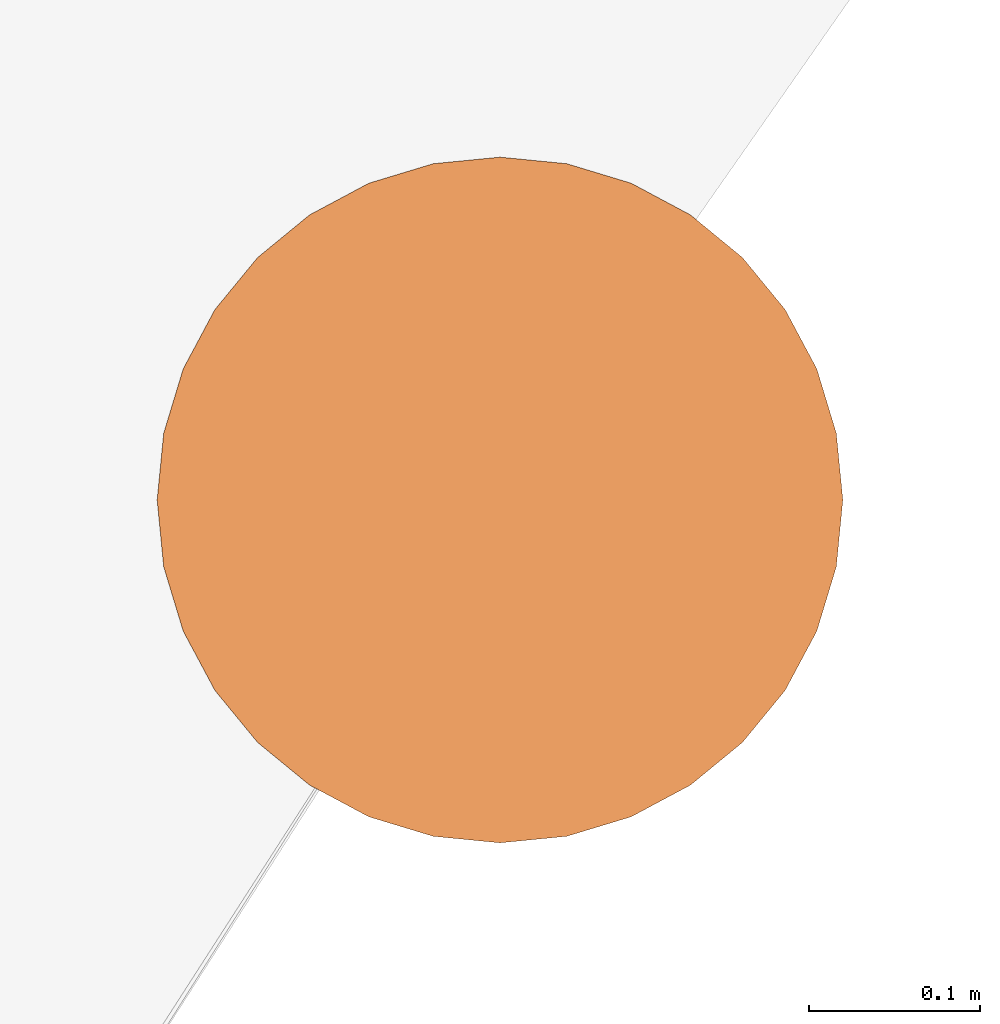
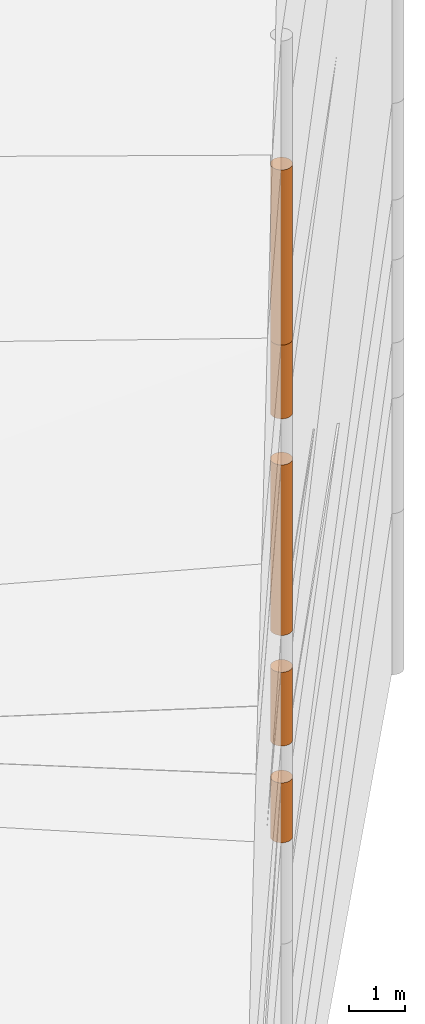
# One storey, part 16 of 24: 5 geographic elements.
"""IFC4 building model written with IfcOpenShell, lengths in metres."""

from ifc_helpers import new_model, entity, si_unit, converted_unit, frame, origin_with_axes, origin_2d_with_axis, place, context, subcontext, project, spatial, polygons, element, save


model = new_model("IFC4")

# Units and contexts
model_context = context("Model", 3, precision=1e-05, world=origin_with_axes())
plan_context = context("Plan", 2, precision=1e-05, world=origin_2d_with_axis())
body_context = subcontext(model_context, "Body", "Model", "MODEL_VIEW")
ifc_project = project(units=[converted_unit("PLANEANGLEUNIT", "degree", entity("IfcReal", 0.0174532925199433), si_unit("PLANEANGLEUNIT", "RADIAN"), dimensions=[0, 0, 0, 0, 0, 0, 0]), si_unit("AREAUNIT", "SQUARE_METRE"), si_unit("VOLUMEUNIT", "CUBIC_METRE"), si_unit("LENGTHUNIT", "METRE")], contexts=[model_context, plan_context])

# Site, building, storey
site_placement = place(None, origin_with_axes())
site = spatial("IfcSite", under=ifc_project, at=site_placement)
building_placement = place(site_placement, origin_with_axes())
building = spatial("IfcBuilding", under=site, at=building_placement, Name="Building")
storey_placement = place(building_placement, origin_with_axes())
storey = spatial("IfcBuildingStorey", under=building, at=storey_placement, Name="Storey")

# Geographic elements
geographic_element_1_placement = place(storey_placement, frame((36.5, 56.7999992370605, 0.150000095367432), z_axis=(0.0, 0.0, 1.0), x_axis=(1.0, 0.0, 0.0)))
element("IfcGeographicElement", 1, at=geographic_element_1_placement, inside=storey, PredefinedType="NOTDEFINED", context=body_context, shape_type="Tessellation", body=[
    polygons([(0.0, 0.0, -0.649999916553497), (0.0390180610120296, 0.196157038211823, -0.649999916553497), (0.0, 0.199999988079071, -0.649999916553497), (0.0, 0.0, 0.649999916553497), (0.0, 0.199999988079071, 0.649999916553497), (0.0390180610120296, 0.196157038211823, 0.649999916553497), (0.0765366926789284, 0.18477588891983, -0.649999916553497), (0.0765366926789284, 0.18477588891983, 0.649999916553497), (0.111114047467709, 0.166293919086456, -0.649999916553497), (0.111114047467709, 0.166293919086456, 0.649999916553497), (0.141421362757683, 0.141421362757683, -0.649999916553497), (0.141421362757683, 0.141421362757683, 0.649999916553497), (0.166293919086456, 0.111114047467709, -0.649999916553497), (0.166293919086456, 0.111114047467709, 0.649999916553497), (0.18477588891983, 0.0765366926789284, -0.649999916553497), (0.18477588891983, 0.0765366926789284, 0.649999916553497), (0.196157038211823, 0.0390180610120296, -0.649999916553497), (0.196157038211823, 0.0390180610120296, 0.649999916553497), (0.199999988079071, 0.0, -0.649999916553497), (0.199999988079071, 0.0, 0.649999916553497), (0.196157038211823, -0.0390180610120296, -0.649999916553497), (0.196157038211823, -0.0390180610120296, 0.649999916553497), (0.18477588891983, -0.0765366926789284, -0.649999916553497), (0.18477588891983, -0.0765366926789284, 0.649999916553497), (0.166293919086456, -0.111114047467709, -0.649999916553497), (0.166293919086456, -0.111114047467709, 0.649999916553497), (0.141421362757683, -0.141421362757683, -0.649999916553497), (0.141421362757683, -0.141421362757683, 0.649999916553497), (0.111114047467709, -0.166293919086456, -0.649999916553497), (0.111114047467709, -0.166293919086456, 0.649999916553497), (0.0765366926789284, -0.18477588891983, -0.649999916553497), (0.0765366926789284, -0.18477588891983, 0.649999916553497), (0.0390180610120296, -0.196157038211823, -0.649999916553497), (0.0390180610120296, -0.196157038211823, 0.649999916553497), (0.0, -0.199999988079071, -0.649999916553497), (0.0, -0.199999988079071, 0.649999916553497), (-0.0390180610120296, -0.196157038211823, -0.649999916553497), (-0.0390180610120296, -0.196157038211823, 0.649999916553497), (-0.0765366926789284, -0.18477588891983, -0.649999916553497), (-0.0765366926789284, -0.18477588891983, 0.649999916553497), (-0.111114047467709, -0.166293919086456, -0.649999916553497), (-0.111114047467709, -0.166293919086456, 0.649999916553497), (-0.141421362757683, -0.141421362757683, -0.649999916553497), (-0.141421362757683, -0.141421362757683, 0.649999916553497), (-0.166293919086456, -0.111114047467709, -0.649999916553497), (-0.166293919086456, -0.111114047467709, 0.649999916553497), (-0.18477588891983, -0.0765366926789284, -0.649999916553497), (-0.18477588891983, -0.0765366926789284, 0.649999916553497), (-0.196157038211823, -0.0390180610120296, -0.649999916553497), (-0.196157038211823, -0.0390180610120296, 0.649999916553497), (-0.199999988079071, 0.0, -0.649999916553497), (-0.199999988079071, 0.0, 0.649999916553497), (-0.196157038211823, 0.0390180610120296, -0.649999916553497), (-0.196157038211823, 0.0390180610120296, 0.649999916553497), (-0.18477588891983, 0.0765366926789284, -0.649999916553497), (-0.18477588891983, 0.0765366926789284, 0.649999916553497), (-0.166293919086456, 0.111114047467709, -0.649999916553497), (-0.166293919086456, 0.111114047467709, 0.649999916553497), (-0.141421362757683, 0.141421362757683, -0.649999916553497), (-0.141421362757683, 0.141421362757683, 0.649999916553497), (-0.111114047467709, 0.166293919086456, -0.649999916553497), (-0.111114047467709, 0.166293919086456, 0.649999916553497), (-0.0765366926789284, 0.18477588891983, -0.649999916553497), (-0.0765366926789284, 0.18477588891983, 0.649999916553497), (-0.0390180610120296, 0.196157038211823, -0.649999916553497), (-0.0390180610120296, 0.196157038211823, 0.649999916553497)], [[[3, 2, 1]], [[6, 5, 4]], [[32, 34, 33, 31]], [[2, 7, 1]], [[8, 6, 4]], [[64, 66, 65, 63]], [[7, 9, 1]], [[10, 8, 4]], [[9, 11, 1]], [[12, 10, 4]], [[40, 42, 41, 39]], [[1, 11, 13]], [[12, 4, 14]], [[10, 12, 11, 9]], [[1, 13, 15]], [[4, 16, 14]], [[12, 14, 13, 11]], [[1, 15, 17]], [[4, 18, 16]], [[18, 20, 19, 17]], [[1, 17, 19]], [[4, 20, 18]], [[20, 22, 21, 19]], [[1, 19, 21]], [[4, 22, 20]], [[22, 24, 23, 21]], [[1, 21, 23]], [[22, 4, 24]], [[54, 56, 55, 53]], [[1, 23, 25]], [[24, 4, 26]], [[56, 58, 57, 55]], [[1, 25, 27]], [[4, 28, 26]], [[24, 26, 25, 23]], [[1, 27, 29]], [[28, 4, 30]], [[26, 28, 27, 25]], [[1, 29, 31]], [[4, 32, 30]], [[46, 48, 47, 45]], [[1, 31, 33]], [[4, 34, 32]], [[36, 38, 37, 35]], [[1, 33, 35]], [[4, 36, 34]], [[42, 44, 43, 41]], [[1, 35, 37]], [[4, 38, 36]], [[38, 40, 39, 37]], [[1, 37, 39]], [[4, 40, 38]], [[34, 36, 35, 33]], [[1, 39, 41]], [[4, 42, 40]], [[8, 10, 9, 7]], [[43, 1, 41]], [[4, 44, 42]], [[44, 46, 45, 43]], [[43, 45, 1]], [[4, 46, 44]], [[30, 32, 31, 29]], [[47, 1, 45]], [[48, 46, 4]], [[28, 30, 29, 27]], [[49, 1, 47]], [[50, 48, 4]], [[5, 6, 2, 3]], [[49, 51, 1]], [[52, 50, 4]], [[48, 50, 49, 47]], [[51, 53, 1]], [[54, 52, 4]], [[50, 52, 51, 49]], [[53, 55, 1]], [[4, 56, 54]], [[52, 54, 53, 51]], [[55, 57, 1]], [[4, 58, 56]], [[58, 60, 59, 57]], [[59, 1, 57]], [[60, 58, 4]], [[60, 62, 61, 59]], [[59, 61, 1]], [[62, 60, 4]], [[62, 64, 63, 61]], [[61, 63, 1]], [[64, 62, 4]], [[14, 16, 15, 13]], [[63, 65, 1]], [[66, 64, 4]], [[16, 18, 17, 15]], [[65, 3, 1]], [[5, 66, 4]], [[6, 8, 7, 2]], [[66, 5, 3, 65]]]),
])
geographic_element_2_placement = place(storey_placement, frame((36.5, 56.7999992370605, 2.40000009536743), z_axis=(0.0, 0.0, 1.0), x_axis=(1.0, 0.0, 0.0)))
element("IfcGeographicElement", 2, at=geographic_element_2_placement, inside=storey, PredefinedType="NOTDEFINED", context=body_context, shape_type="Tessellation", body=[
    polygons([(0.0, 0.0, -0.799999952316284), (0.0390180610120296, 0.196157038211823, -0.799999952316284), (0.0, 0.199999988079071, -0.799999952316284), (0.0, 0.0, 0.799999952316284), (0.0, 0.199999988079071, 0.799999952316284), (0.0390180610120296, 0.196157038211823, 0.799999952316284), (0.0765366926789284, 0.18477588891983, -0.799999952316284), (0.0765366926789284, 0.18477588891983, 0.799999952316284), (0.111114047467709, 0.166293919086456, -0.799999952316284), (0.111114047467709, 0.166293919086456, 0.799999952316284), (0.141421362757683, 0.141421362757683, -0.799999952316284), (0.141421362757683, 0.141421362757683, 0.799999952316284), (0.166293919086456, 0.111114047467709, -0.799999952316284), (0.166293919086456, 0.111114047467709, 0.799999952316284), (0.18477588891983, 0.0765366926789284, -0.799999952316284), (0.18477588891983, 0.0765366926789284, 0.799999952316284), (0.196157038211823, 0.0390180610120296, -0.799999952316284), (0.196157038211823, 0.0390180610120296, 0.799999952316284), (0.199999988079071, 0.0, -0.799999952316284), (0.199999988079071, 0.0, 0.799999952316284), (0.196157038211823, -0.0390180610120296, -0.799999952316284), (0.196157038211823, -0.0390180610120296, 0.799999952316284), (0.18477588891983, -0.0765366926789284, -0.799999952316284), (0.18477588891983, -0.0765366926789284, 0.799999952316284), (0.166293919086456, -0.111114047467709, -0.799999952316284), (0.166293919086456, -0.111114047467709, 0.799999952316284), (0.141421362757683, -0.141421362757683, -0.799999952316284), (0.141421362757683, -0.141421362757683, 0.799999952316284), (0.111114047467709, -0.166293919086456, -0.799999952316284), (0.111114047467709, -0.166293919086456, 0.799999952316284), (0.0765366926789284, -0.18477588891983, -0.799999952316284), (0.0765366926789284, -0.18477588891983, 0.799999952316284), (0.0390180610120296, -0.196157038211823, -0.799999952316284), (0.0390180610120296, -0.196157038211823, 0.799999952316284), (0.0, -0.199999988079071, -0.799999952316284), (0.0, -0.199999988079071, 0.799999952316284), (-0.0390180610120296, -0.196157038211823, -0.799999952316284), (-0.0390180610120296, -0.196157038211823, 0.799999952316284), (-0.0765366926789284, -0.18477588891983, -0.799999952316284), (-0.0765366926789284, -0.18477588891983, 0.799999952316284), (-0.111114047467709, -0.166293919086456, -0.799999952316284), (-0.111114047467709, -0.166293919086456, 0.799999952316284), (-0.141421362757683, -0.141421362757683, -0.799999952316284), (-0.141421362757683, -0.141421362757683, 0.799999952316284), (-0.166293919086456, -0.111114047467709, -0.799999952316284), (-0.166293919086456, -0.111114047467709, 0.799999952316284), (-0.18477588891983, -0.0765366926789284, -0.799999952316284), (-0.18477588891983, -0.0765366926789284, 0.799999952316284), (-0.196157038211823, -0.0390180610120296, -0.799999952316284), (-0.196157038211823, -0.0390180610120296, 0.799999952316284), (-0.199999988079071, 0.0, -0.799999952316284), (-0.199999988079071, 0.0, 0.799999952316284), (-0.196157038211823, 0.0390180610120296, -0.799999952316284), (-0.196157038211823, 0.0390180610120296, 0.799999952316284), (-0.18477588891983, 0.0765366926789284, -0.799999952316284), (-0.18477588891983, 0.0765366926789284, 0.799999952316284), (-0.166293919086456, 0.111114047467709, -0.799999952316284), (-0.166293919086456, 0.111114047467709, 0.799999952316284), (-0.141421362757683, 0.141421362757683, -0.799999952316284), (-0.141421362757683, 0.141421362757683, 0.799999952316284), (-0.111114047467709, 0.166293919086456, -0.799999952316284), (-0.111114047467709, 0.166293919086456, 0.799999952316284), (-0.0765366926789284, 0.18477588891983, -0.799999952316284), (-0.0765366926789284, 0.18477588891983, 0.799999952316284), (-0.0390180610120296, 0.196157038211823, -0.799999952316284), (-0.0390180610120296, 0.196157038211823, 0.799999952316284)], [[[3, 2, 1]], [[6, 5, 4]], [[28, 30, 29, 27]], [[2, 7, 1]], [[8, 6, 4]], [[36, 38, 37, 35]], [[7, 9, 1]], [[10, 8, 4]], [[56, 58, 57, 55]], [[9, 11, 1]], [[12, 10, 4]], [[58, 60, 59, 57]], [[11, 13, 1]], [[12, 4, 14]], [[54, 56, 55, 53]], [[1, 13, 15]], [[14, 4, 16]], [[10, 12, 11, 9]], [[1, 15, 17]], [[4, 18, 16]], [[60, 62, 61, 59]], [[1, 17, 19]], [[4, 20, 18]], [[16, 18, 17, 15]], [[1, 19, 21]], [[4, 22, 20]], [[18, 20, 19, 17]], [[1, 21, 23]], [[4, 24, 22]], [[20, 22, 21, 19]], [[1, 23, 25]], [[24, 4, 26]], [[22, 24, 23, 21]], [[27, 1, 25]], [[26, 4, 28]], [[24, 26, 25, 23]], [[1, 27, 29]], [[28, 4, 30]], [[62, 64, 63, 61]], [[1, 29, 31]], [[4, 32, 30]], [[64, 66, 65, 63]], [[1, 31, 33]], [[4, 34, 32]], [[30, 32, 31, 29]], [[1, 33, 35]], [[4, 36, 34]], [[8, 10, 9, 7]], [[1, 35, 37]], [[4, 38, 36]], [[32, 34, 33, 31]], [[1, 37, 39]], [[4, 40, 38]], [[6, 8, 7, 2]], [[1, 39, 41]], [[4, 42, 40]], [[38, 40, 39, 37]], [[43, 1, 41]], [[4, 44, 42]], [[40, 42, 41, 39]], [[45, 1, 43]], [[46, 44, 4]], [[42, 44, 43, 41]], [[47, 1, 45]], [[4, 48, 46]], [[44, 46, 45, 43]], [[47, 49, 1]], [[50, 48, 4]], [[46, 48, 47, 45]], [[49, 51, 1]], [[52, 50, 4]], [[48, 50, 49, 47]], [[51, 53, 1]], [[54, 52, 4]], [[66, 5, 3, 65]], [[53, 55, 1]], [[56, 54, 4]], [[52, 54, 53, 51]], [[57, 1, 55]], [[4, 58, 56]], [[57, 59, 1]], [[60, 58, 4]], [[34, 36, 35, 33]], [[59, 61, 1]], [[62, 60, 4]], [[14, 16, 15, 13]], [[61, 63, 1]], [[64, 62, 4]], [[26, 28, 27, 25]], [[63, 65, 1]], [[66, 64, 4]], [[5, 6, 2, 3]], [[65, 3, 1]], [[5, 66, 4]], [[50, 52, 51, 49]], [[12, 14, 13, 11]]]),
])
geographic_element_3_placement = place(storey_placement, frame((36.5, 56.7999992370605, 5.85000038146973), z_axis=(0.0, 0.0, 1.0), x_axis=(1.0, 0.0, 0.0)))
element("IfcGeographicElement", 3, at=geographic_element_3_placement, inside=storey, PredefinedType="NOTDEFINED", context=body_context, shape_type="Tessellation", body=[
    polygons([(0.0, 0.0, -1.84999990463257), (0.0390180610120296, 0.196157038211823, -1.84999990463257), (0.0, 0.199999988079071, -1.84999990463257), (0.0, 0.0, 1.84999990463257), (0.0, 0.199999988079071, 1.84999990463257), (0.0390180610120296, 0.196157038211823, 1.84999990463257), (0.0765366926789284, 0.18477588891983, -1.84999990463257), (0.0765366926789284, 0.18477588891983, 1.84999990463257), (0.111114047467709, 0.166293919086456, -1.84999990463257), (0.111114047467709, 0.166293919086456, 1.84999990463257), (0.141421362757683, 0.141421362757683, -1.84999990463257), (0.141421362757683, 0.141421362757683, 1.84999990463257), (0.166293919086456, 0.111114047467709, -1.84999990463257), (0.166293919086456, 0.111114047467709, 1.84999990463257), (0.18477588891983, 0.0765366926789284, -1.84999990463257), (0.18477588891983, 0.0765366926789284, 1.84999990463257), (0.196157038211823, 0.0390180610120296, -1.84999990463257), (0.196157038211823, 0.0390180610120296, 1.84999990463257), (0.199999988079071, 0.0, -1.84999990463257), (0.199999988079071, 0.0, 1.84999990463257), (0.196157038211823, -0.0390180610120296, -1.84999990463257), (0.196157038211823, -0.0390180610120296, 1.84999990463257), (0.18477588891983, -0.0765366926789284, -1.84999990463257), (0.18477588891983, -0.0765366926789284, 1.84999990463257), (0.166293919086456, -0.111114047467709, -1.84999990463257), (0.166293919086456, -0.111114047467709, 1.84999990463257), (0.141421362757683, -0.141421362757683, -1.84999990463257), (0.141421362757683, -0.141421362757683, 1.84999990463257), (0.111114047467709, -0.166293919086456, -1.84999990463257), (0.111114047467709, -0.166293919086456, 1.84999990463257), (0.0765366926789284, -0.18477588891983, -1.84999990463257), (0.0765366926789284, -0.18477588891983, 1.84999990463257), (0.0390180610120296, -0.196157038211823, -1.84999990463257), (0.0390180610120296, -0.196157038211823, 1.84999990463257), (0.0, -0.199999988079071, -1.84999990463257), (0.0, -0.199999988079071, 1.84999990463257), (-0.0390180610120296, -0.196157038211823, -1.84999990463257), (-0.0390180610120296, -0.196157038211823, 1.84999990463257), (-0.0765366926789284, -0.18477588891983, -1.84999990463257), (-0.0765366926789284, -0.18477588891983, 1.84999990463257), (-0.111114047467709, -0.166293919086456, -1.84999990463257), (-0.111114047467709, -0.166293919086456, 1.84999990463257), (-0.141421362757683, -0.141421362757683, -1.84999990463257), (-0.141421362757683, -0.141421362757683, 1.84999990463257), (-0.166293919086456, -0.111114047467709, -1.84999990463257), (-0.166293919086456, -0.111114047467709, 1.84999990463257), (-0.18477588891983, -0.0765366926789284, -1.84999990463257), (-0.18477588891983, -0.0765366926789284, 1.84999990463257), (-0.196157038211823, -0.0390180610120296, -1.84999990463257), (-0.196157038211823, -0.0390180610120296, 1.84999990463257), (-0.199999988079071, 0.0, -1.84999990463257), (-0.199999988079071, 0.0, 1.84999990463257), (-0.196157038211823, 0.0390180610120296, -1.84999990463257), (-0.196157038211823, 0.0390180610120296, 1.84999990463257), (-0.18477588891983, 0.0765366926789284, -1.84999990463257), (-0.18477588891983, 0.0765366926789284, 1.84999990463257), (-0.166293919086456, 0.111114047467709, -1.84999990463257), (-0.166293919086456, 0.111114047467709, 1.84999990463257), (-0.141421362757683, 0.141421362757683, -1.84999990463257), (-0.141421362757683, 0.141421362757683, 1.84999990463257), (-0.111114047467709, 0.166293919086456, -1.84999990463257), (-0.111114047467709, 0.166293919086456, 1.84999990463257), (-0.0765366926789284, 0.18477588891983, -1.84999990463257), (-0.0765366926789284, 0.18477588891983, 1.84999990463257), (-0.0390180610120296, 0.196157038211823, -1.84999990463257), (-0.0390180610120296, 0.196157038211823, 1.84999990463257)], [[[3, 2, 1]], [[6, 5, 4]], [[62, 64, 63, 61]], [[2, 7, 1]], [[8, 6, 4]], [[30, 32, 31, 29]], [[7, 9, 1]], [[10, 8, 4]], [[10, 12, 11, 9]], [[9, 11, 1]], [[12, 10, 4]], [[11, 13, 1]], [[12, 4, 14]], [[66, 5, 3, 65]], [[1, 13, 15]], [[4, 16, 14]], [[42, 44, 43, 41]], [[1, 15, 17]], [[4, 18, 16]], [[48, 50, 49, 47]], [[1, 17, 19]], [[4, 20, 18]], [[16, 18, 17, 15]], [[1, 19, 21]], [[4, 22, 20]], [[50, 52, 51, 49]], [[1, 21, 23]], [[22, 4, 24]], [[54, 56, 55, 53]], [[1, 23, 25]], [[24, 4, 26]], [[56, 58, 57, 55]], [[27, 1, 25]], [[26, 4, 28]], [[58, 60, 59, 57]], [[1, 27, 29]], [[28, 4, 30]], [[60, 62, 61, 59]], [[1, 29, 31]], [[4, 32, 30]], [[64, 66, 65, 63]], [[1, 31, 33]], [[4, 34, 32]], [[6, 8, 7, 2]], [[1, 33, 35]], [[4, 36, 34]], [[8, 10, 9, 7]], [[1, 35, 37]], [[4, 38, 36]], [[32, 34, 33, 31]], [[1, 37, 39]], [[4, 40, 38]], [[36, 38, 37, 35]], [[1, 39, 41]], [[4, 42, 40]], [[46, 48, 47, 45]], [[43, 1, 41]], [[4, 44, 42]], [[34, 36, 35, 33]], [[45, 1, 43]], [[46, 44, 4]], [[14, 16, 15, 13]], [[47, 1, 45]], [[48, 46, 4]], [[44, 46, 45, 43]], [[49, 1, 47]], [[50, 48, 4]], [[40, 42, 41, 39]], [[49, 51, 1]], [[52, 50, 4]], [[18, 20, 19, 17]], [[51, 53, 1]], [[54, 52, 4]], [[20, 22, 21, 19]], [[53, 55, 1]], [[4, 56, 54]], [[52, 54, 53, 51]], [[55, 57, 1]], [[4, 58, 56]], [[22, 24, 23, 21]], [[57, 59, 1]], [[60, 58, 4]], [[24, 26, 25, 23]], [[59, 61, 1]], [[62, 60, 4]], [[26, 28, 27, 25]], [[61, 63, 1]], [[64, 62, 4]], [[28, 30, 29, 27]], [[63, 65, 1]], [[66, 64, 4]], [[5, 6, 2, 3]], [[65, 3, 1]], [[5, 66, 4]], [[38, 40, 39, 37]], [[12, 14, 13, 11]]]),
])
geographic_element_4_placement = place(storey_placement, frame((36.5, 56.7999992370605, 9.50000095367432), z_axis=(0.0, 0.0, 1.0), x_axis=(1.0, 0.0, 0.0)))
element("IfcGeographicElement", 4, at=geographic_element_4_placement, inside=storey, PredefinedType="NOTDEFINED", context=body_context, shape_type="Tessellation", body=[
    polygons([(0.0, 0.0, -0.799999952316284), (0.0390180610120296, 0.196157038211823, -0.799999952316284), (0.0, 0.199999988079071, -0.799999952316284), (0.0, 0.0, 0.799999952316284), (0.0, 0.199999988079071, 0.799999952316284), (0.0390180610120296, 0.196157038211823, 0.799999952316284), (0.0765366926789284, 0.18477588891983, -0.799999952316284), (0.0765366926789284, 0.18477588891983, 0.799999952316284), (0.111114047467709, 0.166293919086456, -0.799999952316284), (0.111114047467709, 0.166293919086456, 0.799999952316284), (0.141421362757683, 0.141421362757683, -0.799999952316284), (0.141421362757683, 0.141421362757683, 0.799999952316284), (0.166293919086456, 0.111114047467709, -0.799999952316284), (0.166293919086456, 0.111114047467709, 0.799999952316284), (0.18477588891983, 0.0765366926789284, -0.799999952316284), (0.18477588891983, 0.0765366926789284, 0.799999952316284), (0.196157038211823, 0.0390180610120296, -0.799999952316284), (0.196157038211823, 0.0390180610120296, 0.799999952316284), (0.199999988079071, 0.0, -0.799999952316284), (0.199999988079071, 0.0, 0.799999952316284), (0.196157038211823, -0.0390180610120296, -0.799999952316284), (0.196157038211823, -0.0390180610120296, 0.799999952316284), (0.18477588891983, -0.0765366926789284, -0.799999952316284), (0.18477588891983, -0.0765366926789284, 0.799999952316284), (0.166293919086456, -0.111114047467709, -0.799999952316284), (0.166293919086456, -0.111114047467709, 0.799999952316284), (0.141421362757683, -0.141421362757683, -0.799999952316284), (0.141421362757683, -0.141421362757683, 0.799999952316284), (0.111114047467709, -0.166293919086456, -0.799999952316284), (0.111114047467709, -0.166293919086456, 0.799999952316284), (0.0765366926789284, -0.18477588891983, -0.799999952316284), (0.0765366926789284, -0.18477588891983, 0.799999952316284), (0.0390180610120296, -0.196157038211823, -0.799999952316284), (0.0390180610120296, -0.196157038211823, 0.799999952316284), (0.0, -0.199999988079071, -0.799999952316284), (0.0, -0.199999988079071, 0.799999952316284), (-0.0390180610120296, -0.196157038211823, -0.799999952316284), (-0.0390180610120296, -0.196157038211823, 0.799999952316284), (-0.0765366926789284, -0.18477588891983, -0.799999952316284), (-0.0765366926789284, -0.18477588891983, 0.799999952316284), (-0.111114047467709, -0.166293919086456, -0.799999952316284), (-0.111114047467709, -0.166293919086456, 0.799999952316284), (-0.141421362757683, -0.141421362757683, -0.799999952316284), (-0.141421362757683, -0.141421362757683, 0.799999952316284), (-0.166293919086456, -0.111114047467709, -0.799999952316284), (-0.166293919086456, -0.111114047467709, 0.799999952316284), (-0.18477588891983, -0.0765366926789284, -0.799999952316284), (-0.18477588891983, -0.0765366926789284, 0.799999952316284), (-0.196157038211823, -0.0390180610120296, -0.799999952316284), (-0.196157038211823, -0.0390180610120296, 0.799999952316284), (-0.199999988079071, 0.0, -0.799999952316284), (-0.199999988079071, 0.0, 0.799999952316284), (-0.196157038211823, 0.0390180610120296, -0.799999952316284), (-0.196157038211823, 0.0390180610120296, 0.799999952316284), (-0.18477588891983, 0.0765366926789284, -0.799999952316284), (-0.18477588891983, 0.0765366926789284, 0.799999952316284), (-0.166293919086456, 0.111114047467709, -0.799999952316284), (-0.166293919086456, 0.111114047467709, 0.799999952316284), (-0.141421362757683, 0.141421362757683, -0.799999952316284), (-0.141421362757683, 0.141421362757683, 0.799999952316284), (-0.111114047467709, 0.166293919086456, -0.799999952316284), (-0.111114047467709, 0.166293919086456, 0.799999952316284), (-0.0765366926789284, 0.18477588891983, -0.799999952316284), (-0.0765366926789284, 0.18477588891983, 0.799999952316284), (-0.0390180610120296, 0.196157038211823, -0.799999952316284), (-0.0390180610120296, 0.196157038211823, 0.799999952316284)], [[[3, 2, 1]], [[6, 5, 4]], [[28, 30, 29, 27]], [[2, 7, 1]], [[8, 6, 4]], [[36, 38, 37, 35]], [[7, 9, 1]], [[10, 8, 4]], [[56, 58, 57, 55]], [[9, 11, 1]], [[12, 10, 4]], [[58, 60, 59, 57]], [[11, 13, 1]], [[12, 4, 14]], [[54, 56, 55, 53]], [[1, 13, 15]], [[14, 4, 16]], [[10, 12, 11, 9]], [[1, 15, 17]], [[4, 18, 16]], [[60, 62, 61, 59]], [[1, 17, 19]], [[4, 20, 18]], [[16, 18, 17, 15]], [[1, 19, 21]], [[4, 22, 20]], [[18, 20, 19, 17]], [[1, 21, 23]], [[4, 24, 22]], [[20, 22, 21, 19]], [[1, 23, 25]], [[24, 4, 26]], [[22, 24, 23, 21]], [[27, 1, 25]], [[26, 4, 28]], [[24, 26, 25, 23]], [[1, 27, 29]], [[28, 4, 30]], [[62, 64, 63, 61]], [[1, 29, 31]], [[4, 32, 30]], [[64, 66, 65, 63]], [[1, 31, 33]], [[4, 34, 32]], [[30, 32, 31, 29]], [[1, 33, 35]], [[4, 36, 34]], [[8, 10, 9, 7]], [[1, 35, 37]], [[4, 38, 36]], [[32, 34, 33, 31]], [[1, 37, 39]], [[4, 40, 38]], [[6, 8, 7, 2]], [[1, 39, 41]], [[4, 42, 40]], [[38, 40, 39, 37]], [[43, 1, 41]], [[4, 44, 42]], [[40, 42, 41, 39]], [[45, 1, 43]], [[46, 44, 4]], [[42, 44, 43, 41]], [[47, 1, 45]], [[4, 48, 46]], [[44, 46, 45, 43]], [[47, 49, 1]], [[50, 48, 4]], [[46, 48, 47, 45]], [[49, 51, 1]], [[52, 50, 4]], [[48, 50, 49, 47]], [[51, 53, 1]], [[54, 52, 4]], [[66, 5, 3, 65]], [[53, 55, 1]], [[56, 54, 4]], [[52, 54, 53, 51]], [[57, 1, 55]], [[4, 58, 56]], [[57, 59, 1]], [[60, 58, 4]], [[34, 36, 35, 33]], [[59, 61, 1]], [[62, 60, 4]], [[14, 16, 15, 13]], [[61, 63, 1]], [[64, 62, 4]], [[26, 28, 27, 25]], [[63, 65, 1]], [[66, 64, 4]], [[5, 6, 2, 3]], [[65, 3, 1]], [[5, 66, 4]], [[50, 52, 51, 49]], [[12, 14, 13, 11]]]),
])
geographic_element_5_placement = place(storey_placement, frame((36.5, 56.7999992370605, 12.2000007629395), z_axis=(0.0, 0.0, 1.0), x_axis=(1.0, 0.0, 0.0)))
element("IfcGeographicElement", 5, at=geographic_element_5_placement, inside=storey, PredefinedType="NOTDEFINED", context=body_context, shape_type="Tessellation", body=[
    polygons([(0.0, 0.0, -1.89999985694885), (0.0390180610120296, 0.196157038211823, -1.89999985694885), (0.0, 0.199999988079071, -1.89999985694885), (0.0, 0.0, 1.89999985694885), (0.0, 0.199999988079071, 1.89999985694885), (0.0390180610120296, 0.196157038211823, 1.89999985694885), (0.0765366926789284, 0.18477588891983, -1.89999985694885), (0.0765366926789284, 0.18477588891983, 1.89999985694885), (0.111114047467709, 0.166293919086456, -1.89999985694885), (0.111114047467709, 0.166293919086456, 1.89999985694885), (0.141421362757683, 0.141421362757683, -1.89999985694885), (0.141421362757683, 0.141421362757683, 1.89999985694885), (0.166293919086456, 0.111114047467709, -1.89999985694885), (0.166293919086456, 0.111114047467709, 1.89999985694885), (0.18477588891983, 0.0765366926789284, -1.89999985694885), (0.18477588891983, 0.0765366926789284, 1.89999985694885), (0.196157038211823, 0.0390180610120296, -1.89999985694885), (0.196157038211823, 0.0390180610120296, 1.89999985694885), (0.199999988079071, 0.0, -1.89999985694885), (0.199999988079071, 0.0, 1.89999985694885), (0.196157038211823, -0.0390180610120296, -1.89999985694885), (0.196157038211823, -0.0390180610120296, 1.89999985694885), (0.18477588891983, -0.0765366926789284, -1.89999985694885), (0.18477588891983, -0.0765366926789284, 1.89999985694885), (0.166293919086456, -0.111114047467709, -1.89999985694885), (0.166293919086456, -0.111114047467709, 1.89999985694885), (0.141421362757683, -0.141421362757683, -1.89999985694885), (0.141421362757683, -0.141421362757683, 1.89999985694885), (0.111114047467709, -0.166293919086456, -1.89999985694885), (0.111114047467709, -0.166293919086456, 1.89999985694885), (0.0765366926789284, -0.18477588891983, -1.89999985694885), (0.0765366926789284, -0.18477588891983, 1.89999985694885), (0.0390180610120296, -0.196157038211823, -1.89999985694885), (0.0390180610120296, -0.196157038211823, 1.89999985694885), (0.0, -0.199999988079071, -1.89999985694885), (0.0, -0.199999988079071, 1.89999985694885), (-0.0390180610120296, -0.196157038211823, -1.89999985694885), (-0.0390180610120296, -0.196157038211823, 1.89999985694885), (-0.0765366926789284, -0.18477588891983, -1.89999985694885), (-0.0765366926789284, -0.18477588891983, 1.89999985694885), (-0.111114047467709, -0.166293919086456, -1.89999985694885), (-0.111114047467709, -0.166293919086456, 1.89999985694885), (-0.141421362757683, -0.141421362757683, -1.89999985694885), (-0.141421362757683, -0.141421362757683, 1.89999985694885), (-0.166293919086456, -0.111114047467709, -1.89999985694885), (-0.166293919086456, -0.111114047467709, 1.89999985694885), (-0.18477588891983, -0.0765366926789284, -1.89999985694885), (-0.18477588891983, -0.0765366926789284, 1.89999985694885), (-0.196157038211823, -0.0390180610120296, -1.89999985694885), (-0.196157038211823, -0.0390180610120296, 1.89999985694885), (-0.199999988079071, 0.0, -1.89999985694885), (-0.199999988079071, 0.0, 1.89999985694885), (-0.196157038211823, 0.0390180610120296, -1.89999985694885), (-0.196157038211823, 0.0390180610120296, 1.89999985694885), (-0.18477588891983, 0.0765366926789284, -1.89999985694885), (-0.18477588891983, 0.0765366926789284, 1.89999985694885), (-0.166293919086456, 0.111114047467709, -1.89999985694885), (-0.166293919086456, 0.111114047467709, 1.89999985694885), (-0.141421362757683, 0.141421362757683, -1.89999985694885), (-0.141421362757683, 0.141421362757683, 1.89999985694885), (-0.111114047467709, 0.166293919086456, -1.89999985694885), (-0.111114047467709, 0.166293919086456, 1.89999985694885), (-0.0765366926789284, 0.18477588891983, -1.89999985694885), (-0.0765366926789284, 0.18477588891983, 1.89999985694885), (-0.0390180610120296, 0.196157038211823, -1.89999985694885), (-0.0390180610120296, 0.196157038211823, 1.89999985694885)], [[[3, 2, 1]], [[6, 5, 4]], [[34, 36, 35, 33]], [[2, 7, 1]], [[8, 6, 4]], [[36, 38, 37, 35]], [[7, 9, 1]], [[10, 8, 4]], [[56, 58, 57, 55]], [[9, 11, 1]], [[12, 10, 4]], [[58, 60, 59, 57]], [[11, 13, 1]], [[12, 4, 14]], [[8, 10, 9, 7]], [[1, 13, 15]], [[4, 16, 14]], [[10, 12, 11, 9]], [[1, 15, 17]], [[16, 4, 18]], [[18, 20, 19, 17]], [[1, 17, 19]], [[4, 20, 18]], [[20, 22, 21, 19]], [[1, 19, 21]], [[4, 22, 20]], [[22, 24, 23, 21]], [[1, 21, 23]], [[4, 24, 22]], [[38, 40, 39, 37]], [[1, 23, 25]], [[4, 26, 24]], [[40, 42, 41, 39]], [[27, 1, 25]], [[26, 4, 28]], [[24, 26, 25, 23]], [[1, 27, 29]], [[28, 4, 30]], [[62, 64, 63, 61]], [[1, 29, 31]], [[4, 32, 30]], [[28, 30, 29, 27]], [[1, 31, 33]], [[4, 34, 32]], [[5, 6, 2, 3]], [[1, 33, 35]], [[4, 36, 34]], [[30, 32, 31, 29]], [[1, 35, 37]], [[4, 38, 36]], [[32, 34, 33, 31]], [[1, 37, 39]], [[4, 40, 38]], [[6, 8, 7, 2]], [[1, 39, 41]], [[4, 42, 40]], [[42, 44, 43, 41]], [[43, 1, 41]], [[4, 44, 42]], [[44, 46, 45, 43]], [[45, 1, 43]], [[46, 44, 4]], [[46, 48, 47, 45]], [[45, 47, 1]], [[48, 46, 4]], [[60, 62, 61, 59]], [[47, 49, 1]], [[4, 50, 48]], [[16, 18, 17, 15]], [[49, 51, 1]], [[52, 50, 4]], [[48, 50, 49, 47]], [[51, 53, 1]], [[54, 52, 4]], [[66, 5, 3, 65]], [[55, 1, 53]], [[56, 54, 4]], [[52, 54, 53, 51]], [[55, 57, 1]], [[58, 56, 4]], [[57, 59, 1]], [[60, 58, 4]], [[12, 14, 13, 11]], [[59, 61, 1]], [[62, 60, 4]], [[14, 16, 15, 13]], [[61, 63, 1]], [[64, 62, 4]], [[26, 28, 27, 25]], [[63, 65, 1]], [[66, 64, 4]], [[54, 56, 55, 53]], [[65, 3, 1]], [[5, 66, 4]], [[50, 52, 51, 49]], [[64, 66, 65, 63]]]),
])

save(model, "model.ifc")
